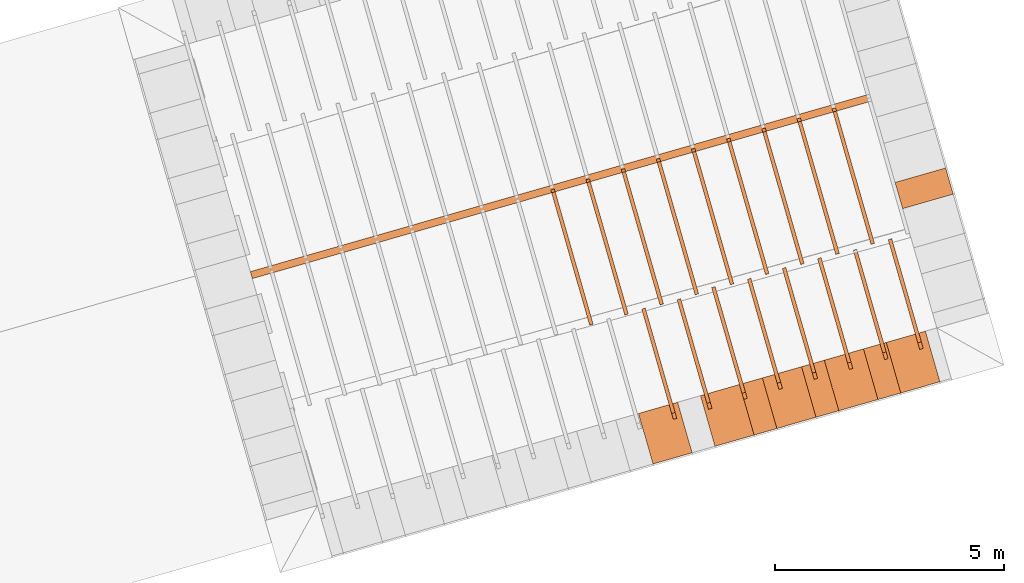
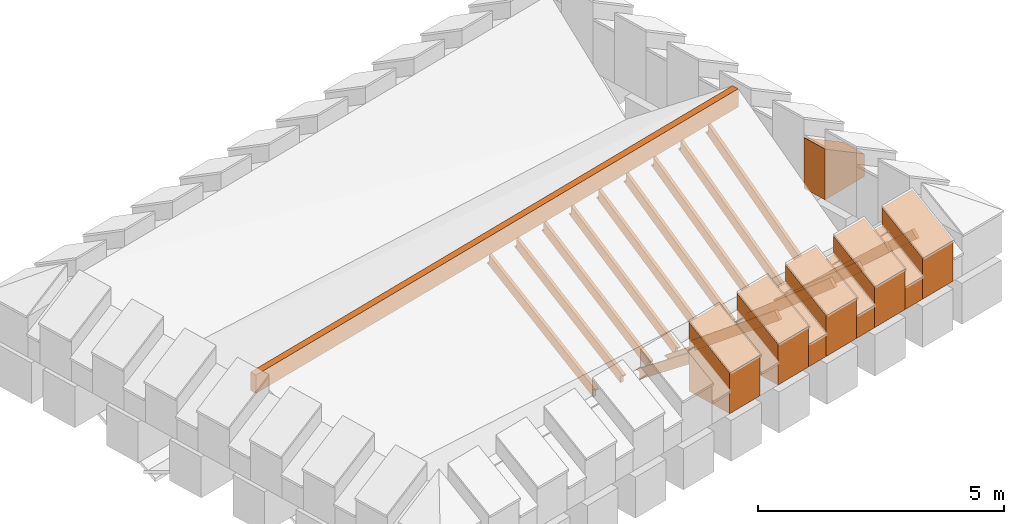
# One storey, part 8 of 10: 27 proxies.
"""IFC4 building model written with IfcOpenShell, lengths in metres."""

from ifc_helpers import new_model, entity, si_unit, converted_unit, derived_unit, direction, frame, origin_with_axes, place, context, subcontext, project, spatial, polygons, material, type_object, element, save


model = new_model("IFC4")

# Units and contexts
model_context = context("Model", 3, precision=1e-05, world=origin_with_axes(), true_north=direction((0.0, 1.0)))
body_context = subcontext(model_context, "Body", "Model", "MODEL_VIEW")
ifc_project = project(units=[si_unit("LENGTHUNIT", "METRE"), si_unit("AREAUNIT", "SQUARE_METRE"), si_unit("VOLUMEUNIT", "CUBIC_METRE"), converted_unit("PLANEANGLEUNIT", "DEGREE", entity("IfcPlaneAngleMeasure", 0.0174532925199433), si_unit("PLANEANGLEUNIT", "RADIAN"), dimensions=[0, 0, 0, 0, 0, 0, 0]), converted_unit("TIMEUNIT", "Year", entity("IfcTimeMeasure", 31557600.0), si_unit("TIMEUNIT", "SECOND"), dimensions=[0, 0, 1, 0, 0, 0, 0]), si_unit("MASSUNIT", "GRAM", prefix="KILO"), si_unit("THERMODYNAMICTEMPERATUREUNIT", "DEGREE_CELSIUS"), si_unit("LUMINOUSINTENSITYUNIT", "LUMEN"), si_unit("ENERGYUNIT", "JOULE", prefix="MEGA"), derived_unit("THERMALCONDUCTANCEUNIT", [(si_unit("POWERUNIT", "WATT"), 1), (si_unit("LENGTHUNIT", "METRE"), -1), (si_unit("THERMODYNAMICTEMPERATUREUNIT", "KELVIN"), -1)]), derived_unit("SPECIFICHEATCAPACITYUNIT", [(si_unit("ENERGYUNIT", "JOULE"), 1), (si_unit("MASSUNIT", "GRAM", prefix="KILO"), -1), (si_unit("THERMODYNAMICTEMPERATUREUNIT", "KELVIN"), -1)]), derived_unit("MASSDENSITYUNIT", [(si_unit("MASSUNIT", "GRAM", prefix="KILO"), 1), (si_unit("VOLUMEUNIT", "CUBIC_METRE"), -1)])], contexts=[model_context])

# Site, building, storey
site_placement = place(None, frame((0.0, 0.0, 0.0), z_axis=(0.0, 0.0, 1.0), x_axis=(0.9612616959383189, 0.2756373558169991, 0.0)))
site = spatial("IfcSite", under=ifc_project, at=site_placement, CompositionType="ELEMENT")
building_placement = place(site_placement, origin_with_axes())
building = spatial("IfcBuilding", under=site, at=building_placement, CompositionType="ELEMENT")
storey_placement = place(building_placement, frame((0.0, 0.0, 11.0), z_axis=(0.0, 0.0, 1.0), x_axis=(1.0, 0.0, 0.0)))
storey = spatial("IfcBuildingStorey", under=building, at=storey_placement, Name="Dach", CompositionType="ELEMENT", Elevation=11.0)

# Proxies
ifc_material_1 = material()
building_element_proxy_type_1 = type_object("IfcBuildingElementProxyType", PredefinedType="NOTDEFINED")
proxy_1_placement = place(storey_placement, frame((-32.66955969550476, -0.05131726657445945, -11.3285), z_axis=(0.0, 0.0, 1.0), x_axis=(1.0, 0.0, 0.0)))
element("IfcBuildingElementProxy", 1, at=proxy_1_placement, inside=storey, type_object=building_element_proxy_type_1, material=ifc_material_1, Name="008", PredefinedType="NOTDEFINED", context=body_context, shape_type="Tessellation", body=[
    polygons([(61.03241932296884, 7.381130212056575, 12.29306372087191), (61.03241932296884, 7.526718754969066, 12.458), (61.03241932296884, 9.89566501934427, 10.36694133970042), (61.03241932296885, 9.787341089745906, 10.36694133970042), (61.03241932296885, 9.787341089745906, 10.16911174696492), (61.11241932296884, 7.381130212056575, 12.29306372087191), (61.11241932296884, 7.526718754969066, 12.458), (61.11241932296884, 9.90232393687027, 10.36106354189202), (61.11241932296885, 9.787341089745906, 10.36106354189202), (61.11241932296885, 9.787341089745906, 10.16911174696491)], [[[1, 2, 3, 4, 5]], [[2, 1, 6, 7]], [[3, 2, 7, 8]], [[4, 3, 8, 9]], [[5, 4, 9, 10]], [[1, 5, 10, 6]], [[6, 10, 9, 8, 7]]], closed=True),
])
proxy_2_placement = place(storey_placement, frame((-32.66955969550476, -0.05131726657445945, -11.3285), z_axis=(0.0, 0.0, 1.0), x_axis=(1.0, 0.0, 0.0)))
element("IfcBuildingElementProxy", 2, at=proxy_2_placement, inside=storey, type_object=building_element_proxy_type_1, material=ifc_material_1, Name="008", PredefinedType="NOTDEFINED", context=body_context, shape_type="Tessellation", body=[
    polygons([(61.83241932296884, 7.37530678639323, 12.38177859929889), (61.83241932296884, 7.526718754969063, 12.5413856660973), (61.83241932296882, 9.862634373866781, 10.32540870856656), (61.83241932296882, 9.861835376853213, 10.30816336161642), (61.83241932296882, 9.787341089745906, 10.30816336161642), (61.83241932296882, 9.787341089745905, 10.09359130616137), (61.91241932296884, 7.375306786393231, 12.38177859929889), (61.91241932296884, 7.526718754969063, 12.5413856660973), (61.91241932296882, 9.862634373866783, 10.32540870856656), (61.91241932296882, 9.861563051633615, 10.30228556380802), (61.91241932296883, 9.787341089745906, 10.30228556380802), (61.91241932296882, 9.787341089745905, 10.09359130616137)], [[[1, 2, 3, 4, 5, 6]], [[2, 1, 7, 8]], [[3, 2, 8, 9]], [[4, 3, 9, 10]], [[5, 4, 10, 11]], [[6, 5, 11, 12]], [[1, 6, 12, 7]], [[7, 12, 11, 10, 9, 8]]], closed=True),
])
proxy_3_placement = place(storey_placement, frame((-32.66955969550476, -0.05131726657445945, -11.3285), z_axis=(0.0, 0.0, 1.0), x_axis=(1.0, 0.0, 0.0)))
element("IfcBuildingElementProxy", 3, at=proxy_3_placement, inside=storey, type_object=building_element_proxy_type_1, material=ifc_material_1, Name="008", PredefinedType="NOTDEFINED", context=body_context, shape_type="Tessellation", body=[
    polygons([(62.63241932296884, 7.377252049091295, 12.29656981746263), (62.63241932296884, 7.526718754969065, 12.458), (62.63241932296887, 9.871470519104868, 10.28701613082583), (62.63241932296887, 9.872561772591819, 10.24938538353242), (62.63241932296887, 9.787341089745906, 10.24938538353242), (62.63241932296887, 9.787341089745905, 10.065090771124), (62.71241932296884, 7.377252049091294, 12.29656981746263), (62.71241932296884, 7.526718754969064, 12.458), (62.71241932296887, 9.871470519104868, 10.28701613082583), (62.71241932296887, 9.872732222763963, 10.24350758572402), (62.71241932296893, 9.787341089745906, 10.24350758572401), (62.71241932296887, 9.787341089745905, 10.06509077112399)], [[[1, 2, 3, 4, 5, 6]], [[2, 1, 7, 8]], [[3, 2, 8, 9]], [[4, 3, 9, 10]], [[5, 4, 10, 11]], [[6, 5, 11, 12]], [[1, 6, 12, 7]], [[7, 12, 11, 10, 9, 8]]], closed=True),
])
proxy_4_placement = place(storey_placement, frame((-32.66955969550476, -0.05131726657445945, -11.3285), z_axis=(0.0, 0.0, 1.0), x_axis=(1.0, 0.0, 0.0)))
element("IfcBuildingElementProxy", 4, at=proxy_4_placement, inside=storey, type_object=building_element_proxy_type_1, material=ifc_material_1, Name="008", PredefinedType="NOTDEFINED", context=body_context, shape_type="Tessellation", body=[
    polygons([(60.23241932296884, 7.383753791211458, 12.29078451286503), (60.23241932296884, 7.526718754969066, 12.458), (60.23241932296884, 9.903726347177741, 10.42571931778442), (60.23241932296884, 9.787341089745906, 10.42571931778442), (60.23241932296884, 9.787341089745906, 10.23577886170872), (60.31241932296884, 7.383753791211458, 12.29078451286503), (60.31241932296884, 7.526718754969066, 12.458), (60.31241932296884, 9.910601170197168, 10.41984151997602), (60.31241932296884, 9.787341089745906, 10.41984151997602), (60.31241932296884, 9.787341089745906, 10.23577886170872)], [[[1, 2, 3, 4, 5]], [[2, 1, 6, 7]], [[3, 2, 7, 8]], [[4, 3, 8, 9]], [[5, 4, 9, 10]], [[1, 5, 10, 6]], [[6, 10, 9, 8, 7]]], closed=True),
])
proxy_5_placement = place(storey_placement, frame((-32.66955969550476, -0.05131726657445945, -11.3285), z_axis=(0.0, 0.0, 1.0), x_axis=(1.0, 0.0, 0.0)))
element("IfcBuildingElementProxy", 5, at=proxy_5_placement, inside=storey, type_object=building_element_proxy_type_1, material=ifc_material_1, Name="008", PredefinedType="NOTDEFINED", context=body_context, shape_type="Tessellation", body=[
    polygons([(59.43241932296884, 7.385575854858428, 12.28924372086243), (59.43241932296884, 7.526718754969064, 12.458), (59.43241932296884, 9.886320073605198, 10.48449729586842), (59.43241932296885, 9.787341089745905, 10.48449729586842), (59.43241932296885, 9.787341089745906, 10.28047632939507), (59.51241932296884, 7.385575854858428, 12.28924372086243), (59.51241932296884, 7.526718754969064, 12.458), (59.51241932296884, 9.893347811358149, 10.47861949806002), (59.51241932296885, 9.787341089745905, 10.47861949806002), (59.51241932296885, 9.787341089745906, 10.28047632939507)], [[[1, 2, 3, 4, 5]], [[2, 1, 6, 7]], [[3, 2, 7, 8]], [[4, 3, 8, 9]], [[5, 4, 9, 10]], [[1, 5, 10, 6]], [[6, 10, 9, 8, 7]]], closed=True),
])
proxy_6_placement = place(storey_placement, frame((-32.66955969550476, -0.05131726657445945, -11.3285), z_axis=(0.0, 0.0, 1.0), x_axis=(1.0, 0.0, 0.0)))
element("IfcBuildingElementProxy", 6, at=proxy_6_placement, inside=storey, type_object=building_element_proxy_type_1, material=ifc_material_1, Name="008", PredefinedType="NOTDEFINED", context=body_context, shape_type="Tessellation", body=[
    polygons([(58.63241932296884, 7.389549320189349, 12.28599841232647), (58.63241932296884, 7.526718754969065, 12.458), (58.63241932296884, 9.9276595576109, 10.54327527395242), (58.63241932296884, 9.787341089745905, 10.54327527395242), (58.63241932296884, 9.787341089745905, 10.37378500663502), (58.71241932296884, 7.389549320189349, 12.28599841232647), (58.71241932296884, 7.526718754969065, 12.458), (58.71241932296884, 9.935029935397266, 10.53739747614402), (58.71241932296884, 9.787341089745905, 10.53739747614402), (58.71241932296884, 9.787341089745905, 10.37378500663502)], [[[1, 2, 3, 4, 5]], [[2, 1, 6, 7]], [[3, 2, 7, 8]], [[4, 3, 8, 9]], [[5, 4, 9, 10]], [[1, 5, 10, 6]], [[7, 6, 10, 9, 8]]], closed=True),
])
proxy_7_placement = place(storey_placement, frame((-32.66955969550476, -0.05131726657445945, -11.3285), z_axis=(0.0, 0.0, 1.0), x_axis=(1.0, 0.0, 0.0)))
element("IfcBuildingElementProxy", 7, at=proxy_7_placement, inside=storey, type_object=building_element_proxy_type_1, material=ifc_material_1, Name="008", PredefinedType="NOTDEFINED", context=body_context, shape_type="Tessellation", body=[
    polygons([(57.83241932296884, 7.390572951635179, 12.28518703684454), (57.83241932296884, 7.526718754969064, 12.458), (57.83241932296884, 9.882514153140576, 10.60205325203643), (57.83241932296884, 9.787341089745905, 10.60205325203643), (57.83241932296884, 9.787341089745905, 10.39696107503057), (57.91241932296884, 7.390572951635179, 12.28518703684454), (57.91241932296884, 7.526718754969064, 12.458), (57.91241932296884, 9.889974975517944, 10.59617545422803), (57.91241932296884, 9.787341089745905, 10.59617545422803), (57.91241932296884, 9.787341089745905, 10.39696107503057)], [[[1, 2, 3, 4, 5]], [[2, 1, 6, 7]], [[3, 2, 7, 8]], [[4, 3, 8, 9]], [[5, 4, 9, 10]], [[1, 5, 10, 6]], [[6, 10, 9, 8, 7]]], closed=True),
])
proxy_8_placement = place(storey_placement, frame((-32.66955969550476, -0.05131726657445945, -11.3285), z_axis=(0.0, 0.0, 1.0), x_axis=(1.0, 0.0, 0.0)))
element("IfcBuildingElementProxy", 8, at=proxy_8_placement, inside=storey, type_object=building_element_proxy_type_1, material=ifc_material_1, Name="008", PredefinedType="NOTDEFINED", context=body_context, shape_type="Tessellation", body=[
    polygons([(57.03241932296884, 7.393757020753038, 12.28272542330884), (57.03241932296884, 7.526718754969065, 12.458), (57.03241932296884, 9.895806351791734, 10.66083123012043), (57.03241932296884, 9.787341089745905, 10.66083123012043), (57.03241932296884, 9.787341089745905, 10.46697384762017), (57.11241932296884, 7.393757020753038, 12.28272542330884), (57.11241932296884, 7.526718754969065, 12.458), (57.11241932296884, 9.90355466019654, 10.65495343231203), (57.11241932296884, 9.787341089745905, 10.65495343231203), (57.11241932296884, 9.787341089745905, 10.46697384762017)], [[[1, 2, 3, 4, 5]], [[2, 1, 6, 7]], [[3, 2, 7, 8]], [[4, 3, 8, 9]], [[5, 4, 9, 10]], [[1, 5, 10, 6]], [[6, 10, 9, 8, 7]]], closed=True),
])
proxy_9_placement = place(storey_placement, frame((79.48385070717022, 25.8856182236699, -11.3285), z_axis=(0.0, 0.0, 1.0), x_axis=(-1.0, 0.0, 0.0)))
element("IfcBuildingElementProxy", 9, at=proxy_9_placement, inside=storey, type_object=building_element_proxy_type_1, material=ifc_material_1, Name="003", PredefinedType="NOTDEFINED", context=body_context, shape_type="Tessellation", body=[
    polygons([(55.43241932244963, 13.0473410897459, 12.42240354413239), (55.43241932244962, 13.0473410897459, 12.642), (55.43241932244962, 16.05704587116529, 10.71221040876106), (55.43241932244962, 16.06016943486015, 10.68366000188212), (55.43241932244962, 15.9873410897459, 10.68366000188212), (55.43241932244962, 15.9873410897459, 10.49556478084415), (55.43241932244962, 12.98223842714421, 12.42240354413239), (55.51241932244962, 13.0473410897459, 12.42240354413239), (55.51241932244962, 13.0473410897459, 12.642), (55.51241932244962, 16.05704587116529, 10.71221040876106), (55.51241932244962, 16.05952637306709, 10.68953779969052), (55.51241932244965, 15.9873410897459, 10.68953779969052), (55.51241932244962, 15.9873410897459, 10.49556478084415), (55.51241932244962, 12.98223842714421, 12.42240354413239)], [[[1, 2, 3, 4, 5, 6, 7]], [[2, 1, 8, 9]], [[3, 2, 9, 10]], [[4, 3, 10, 11]], [[5, 4, 11, 12]], [[6, 5, 12, 13]], [[6, 13, 14, 7]], [[1, 7, 14, 8]], [[10, 9, 8, 14, 13, 12, 11]]], closed=True),
])
proxy_10_placement = place(storey_placement, frame((79.48385070717022, 25.8856182236699, -11.3285), z_axis=(0.0, 0.0, 1.0), x_axis=(-1.0, 0.0, 0.0)))
element("IfcBuildingElementProxy", 10, at=proxy_10_placement, inside=storey, type_object=building_element_proxy_type_1, material=ifc_material_1, Name="003", PredefinedType="NOTDEFINED", context=body_context, shape_type="Tessellation", body=[
    polygons([(52.23241932244962, 15.9873410897459, 10.24879059796566), (52.31241932244962, 15.9873410897459, 10.24879059796566), (52.31241932244962, 12.97568312696457, 12.42240354413239), (52.23241932244962, 12.97568312696457, 12.42240354413239), (52.23241932244962, 15.9873410897459, 10.44854808954612), (52.31241932244964, 15.9873410897459, 10.45442588735452), (52.31241932244962, 16.05704587116523, 10.46979672928334), (52.31241932244962, 13.0473410897459, 12.642), (52.31241932244962, 13.0473410897459, 12.42240354413239), (52.31241932244962, 16.05787615879391, 10.45442588735452), (52.23241932244967, 13.0473410897459, 12.42240354413239), (52.23241932244962, 13.0473410897459, 12.642), (52.23241932244962, 16.05704587116523, 10.46979672928334), (52.23241932244962, 16.05819366012707, 10.44854808954612)], [[[1, 2, 3, 4]], [[1, 5, 6, 2]], [[7, 8, 9, 3, 2, 6, 10]], [[11, 4, 3, 9]], [[11, 12, 13, 14, 5, 1, 4]], [[5, 14, 10, 6]], [[13, 12, 8, 7]], [[12, 11, 9, 8]], [[14, 13, 7, 10]]], closed=True),
])
proxy_11_placement = place(storey_placement, frame((79.48385070717022, 25.8856182236699, -11.3285), z_axis=(0.0, 0.0, 1.0), x_axis=(-1.0, 0.0, 0.0)))
element("IfcBuildingElementProxy", 11, at=proxy_11_placement, inside=storey, type_object=building_element_proxy_type_1, material=ifc_material_1, Name="003", PredefinedType="NOTDEFINED", context=body_context, shape_type="Tessellation", body=[
    polygons([(49.83241932244962, 15.9873410897459, 10.213), (49.83241932244962, 15.7968381574803, 10.213), (49.83241932244962, 12.97102857594039, 12.42240354413239), (49.83241932244954, 13.0473410897459, 12.42240354413239), (49.83241932244962, 13.0473410897459, 12.642), (49.83241932244962, 16.05704587116517, 10.28881510944665), (49.83241932244962, 16.05730391812493, 10.27221415529412), (49.83241932244962, 15.9873410897459, 10.27221415529412), (49.91241932244962, 15.7968381574803, 10.213), (49.91241932244963, 15.9873410897459, 10.213), (49.91241932244962, 12.97102857594039, 12.42240354413239), (49.91241932244962, 13.0473410897459, 12.42240354413239), (49.91241932244962, 13.0473410897459, 12.642), (49.91241932244962, 16.05704587116517, 10.28881510944665), (49.91241932244962, 16.05721255302382, 10.27809195310251), (49.91241932244964, 15.9873410897459, 10.27809195310252)], [[[1, 2, 3, 4, 5, 6, 7, 8]], [[9, 2, 1, 10]], [[2, 9, 11, 3]], [[12, 4, 3, 11]], [[13, 5, 4, 12]], [[6, 5, 13, 14]], [[7, 6, 14, 15]], [[8, 7, 15, 16]], [[1, 8, 16, 10]], [[10, 16, 15, 14, 13, 12, 11, 9]]], closed=True),
])
proxy_12_placement = place(storey_placement, frame((79.48385070717022, 25.8856182236699, -11.3285), z_axis=(0.0, 0.0, 1.0), x_axis=(-1.0, 0.0, 0.0)))
element("IfcBuildingElementProxy", 12, at=proxy_12_placement, inside=storey, type_object=building_element_proxy_type_1, material=ifc_material_1, Name="003", PredefinedType="NOTDEFINED", context=body_context, shape_type="Tessellation", body=[
    polygons([(54.63241932244966, 13.0473410897459, 12.42240354413239), (54.63241932244962, 13.0473410897459, 12.642), (54.63241932244962, 16.05704587116528, 10.65813585979772), (54.63241932244962, 16.06025960763651, 10.62488202379812), (54.63241932244962, 15.9873410897459, 10.62488202379812), (54.63241932244962, 15.9873410897459, 10.440588075492), (54.63241932244962, 12.98074433194067, 12.42240354413239), (54.71241932244962, 13.0473410897459, 12.42240354413239), (54.71241932244962, 13.0473410897459, 12.642), (54.71241932244962, 16.05704587116528, 10.65813585979772), (54.71241932244962, 16.05969156209772, 10.63075982160652), (54.71241932244962, 15.9873410897459, 10.63075982160652), (54.71241932244962, 15.9873410897459, 10.440588075492), (54.71241932244962, 12.98074433194067, 12.42240354413239)], [[[1, 2, 3, 4, 5, 6, 7]], [[2, 1, 8, 9]], [[3, 2, 9, 10]], [[4, 3, 10, 11]], [[5, 4, 11, 12]], [[6, 5, 12, 13]], [[6, 13, 14, 7]], [[1, 7, 14, 8]], [[10, 9, 8, 14, 13, 12, 11]]], closed=True),
])
proxy_13_placement = place(storey_placement, frame((79.48385070717022, 25.8856182236699, -11.3285), z_axis=(0.0, 0.0, 1.0), x_axis=(-1.0, 0.0, 0.0)))
element("IfcBuildingElementProxy", 13, at=proxy_13_placement, inside=storey, type_object=building_element_proxy_type_1, material=ifc_material_1, Name="003", PredefinedType="NOTDEFINED", context=body_context, shape_type="Tessellation", body=[
    polygons([(53.83241932244963, 13.0473410897459, 12.42240354413239), (53.83241932244962, 13.0473410897459, 12.642), (53.83241932244962, 16.05704587116526, 10.58173912076317), (53.83241932244962, 16.05828132135308, 10.56610404571412), (53.83241932244962, 15.9873410897459, 10.56610404571412), (53.83241932244962, 15.9873410897459, 10.36284655167166), (53.83241932244962, 12.97866457198798, 12.42240354413239), (53.91241932244962, 13.0473410897459, 12.42240354413239), (53.91241932244962, 13.0473410897459, 12.642), (53.91241932244962, 16.05704587116526, 10.58173912076317), (53.91241932244962, 16.05781687034254, 10.57198184352252), (53.91241932244963, 15.9873410897459, 10.57198184352252), (53.91241932244962, 15.9873410897459, 10.36284655167166), (53.91241932244962, 12.97866457198798, 12.42240354413239)], [[[1, 2, 3, 4, 5, 6, 7]], [[2, 1, 8, 9]], [[3, 2, 9, 10]], [[4, 3, 10, 11]], [[5, 4, 11, 12]], [[6, 5, 12, 13]], [[6, 13, 14, 7]], [[1, 7, 14, 8]], [[10, 9, 8, 14, 13, 12, 11]]], closed=True),
])
proxy_14_placement = place(storey_placement, frame((79.48385070717022, 25.8856182236699, -11.3285), z_axis=(0.0, 0.0, 1.0), x_axis=(-1.0, 0.0, 0.0)))
element("IfcBuildingElementProxy", 14, at=proxy_14_placement, inside=storey, type_object=building_element_proxy_type_1, material=ifc_material_1, Name="003", PredefinedType="NOTDEFINED", context=body_context, shape_type="Tessellation", body=[
    polygons([(50.63241932244962, 15.9873410897459, 10.213), (50.63241932244962, 15.88094991388374, 10.213), (50.63241932244962, 12.97271999412028, 12.42240354413239), (50.63241932244962, 13.0473410897459, 12.42240354413239), (50.63241932244962, 13.0473410897459, 12.642), (50.63241932244962, 16.05704587116519, 10.35550526116538), (50.63241932244962, 16.05776782380472, 10.33099213337812), (50.63241932244962, 15.9873410897459, 10.33099213337812), (50.71241932244962, 15.88094991388374, 10.213), (50.71241932244963, 15.9873410897459, 10.213), (50.71241932244962, 12.97271999412028, 12.42240354413239), (50.71241932244962, 13.0473410897459, 12.42240354413239), (50.71241932244962, 13.0473410897459, 12.642), (50.71241932244962, 16.05704587116519, 10.35550526116538), (50.71241932244962, 16.05759471282193, 10.33686993118652), (50.71241932244963, 15.9873410897459, 10.33686993118652)], [[[1, 2, 3, 4, 5, 6, 7, 8]], [[9, 2, 1, 10]], [[2, 9, 11, 3]], [[12, 4, 3, 11]], [[4, 12, 13, 5]], [[6, 5, 13, 14]], [[7, 6, 14, 15]], [[8, 7, 15, 16]], [[1, 8, 16, 10]], [[10, 16, 15, 14, 13, 12, 11, 9]]], closed=True),
])
proxy_15_placement = place(storey_placement, frame((79.48385070717022, 25.8856182236699, -11.3285), z_axis=(0.0, 0.0, 1.0), x_axis=(-1.0, 0.0, 0.0)))
element("IfcBuildingElementProxy", 15, at=proxy_15_placement, inside=storey, type_object=building_element_proxy_type_1, material=ifc_material_1, Name="003", PredefinedType="NOTDEFINED", context=body_context, shape_type="Tessellation", body=[
    polygons([(53.03241932244962, 15.9873410897459, 10.32102670754271), (53.11241932244962, 15.9873410897459, 10.32102670754271), (53.11241932244962, 12.97756177222931, 12.42240354413239), (53.03241932244962, 12.97756177222931, 12.42240354413239), (53.03241932244962, 15.9873410897459, 10.50732606763012), (53.11241932244957, 15.9873410897459, 10.51320386543852), (53.11241932244962, 16.05704587116524, 10.54067520324821), (53.11241932244962, 13.0473410897459, 12.642), (53.11241932244962, 13.0473410897459, 12.42240354413239), (53.11241932244962, 16.05896159299123, 10.51320386543852), (53.03241932244961, 13.0473410897459, 12.42240354413239), (53.03241932244962, 13.0473410897459, 12.642), (53.03241932244962, 16.05704587116524, 10.54067520324821), (53.03241932244962, 16.05937148295102, 10.50732606763012)], [[[1, 2, 3, 4]], [[1, 5, 6, 2]], [[7, 8, 9, 3, 2, 6, 10]], [[11, 4, 3, 9]], [[11, 12, 13, 14, 5, 1, 4]], [[5, 14, 10, 6]], [[13, 12, 8, 7]], [[12, 11, 9, 8]], [[14, 13, 7, 10]]], closed=True),
])
proxy_16_placement = place(storey_placement, frame((79.48385070717022, 25.8856182236699, -11.3285), z_axis=(0.0, 0.0, 1.0), x_axis=(-1.0, 0.0, 0.0)))
element("IfcBuildingElementProxy", 16, at=proxy_16_placement, inside=storey, type_object=building_element_proxy_type_1, material=ifc_material_1, Name="003", PredefinedType="NOTDEFINED", context=body_context, shape_type="Tessellation", body=[
    polygons([(51.43241932244962, 15.9873410897459, 10.213), (51.43241932244962, 15.96714171073835, 10.213), (51.43241932244962, 12.97438427181221, 12.42240354413239), (51.43241932244961, 13.0473410897459, 12.42240354413239), (51.43241932244962, 13.0473410897459, 12.642), (51.43241932244962, 16.05704587116521, 10.4200850782058), (51.43241932244962, 16.05835597052995, 10.38977011146212), (51.43241932244962, 15.9873410897459, 10.38977011146212), (51.51241932244962, 15.96714171073835, 10.213), (51.51241932244962, 15.9873410897459, 10.213), (51.51241932244962, 12.97438427181221, 12.42240354413239), (51.51241932244962, 13.0473410897459, 12.42240354413239), (51.51241932244962, 13.0473410897459, 12.642), (51.51241932244962, 16.05704587116521, 10.4200850782058), (51.51241932244962, 16.05810195411489, 10.39564790927052), (51.5124193224496, 15.9873410897459, 10.39564790927052)], [[[1, 2, 3, 4, 5, 6, 7, 8]], [[9, 2, 1, 10]], [[2, 9, 11, 3]], [[12, 4, 3, 11]], [[4, 12, 13, 5]], [[6, 5, 13, 14]], [[7, 6, 14, 15]], [[8, 7, 15, 16]], [[1, 8, 16, 10]], [[10, 16, 15, 14, 13, 12, 11, 9]]], closed=True),
])
proxy_17_placement = place(storey_placement, frame((79.48385070717022, 25.8856182236699, -11.3285), z_axis=(0.0, 0.0, 1.0), x_axis=(-1.0, 0.0, 0.0)))
element("IfcBuildingElementProxy", 17, at=proxy_17_placement, inside=storey, type_object=building_element_proxy_type_1, material=ifc_material_1, Name="003", PredefinedType="NOTDEFINED", context=body_context, shape_type="Tessellation", body=[
    polygons([(56.23241932244962, 13.0473410897459, 12.42240354413239), (56.23241932244962, 13.0473410897459, 12.642), (56.23241932244962, 16.05704587116531, 10.7626932038078), (56.23241932244962, 16.05950773769253, 10.74243797996612), (56.23241932244962, 15.9873410897459, 10.74243797996612), (56.23241932244962, 15.9873410897459, 10.54685159078951), (56.23241932244962, 12.98364967905431, 12.42240354413239), (56.31241932244962, 13.0473410897459, 12.42240354413239), (56.31241932244962, 13.0473410897459, 12.642), (56.31241932244962, 16.05704587116531, 10.7626932038078), (56.31241932244962, 16.05879333661796, 10.74831577777453), (56.31241932244962, 15.9873410897459, 10.74831577777453), (56.31241932244962, 15.9873410897459, 10.54685159078951), (56.31241932244962, 12.98364967905431, 12.42240354413239)], [[[1, 2, 3, 4, 5, 6, 7]], [[2, 1, 8, 9]], [[3, 2, 9, 10]], [[4, 3, 10, 11]], [[5, 4, 11, 12]], [[6, 5, 12, 13]], [[6, 13, 14, 7]], [[1, 7, 14, 8]], [[10, 9, 8, 14, 13, 12, 11]]], closed=True),
])
ifc_material_2 = material(Name="Aluminium")
building_element_proxy_type_2 = type_object("IfcBuildingElementProxyType", Name="Aluminium", PredefinedType="NOTDEFINED")
proxy_18_placement = place(storey_placement, frame((16.3628611917876, 12.99602382325407, 1.313499999999999), z_axis=(0.0, 0.0, 1.0), x_axis=(1.0, 0.0, 0.0)))
element("IfcBuildingElementProxy", 18, at=proxy_18_placement, inside=storey, type_object=building_element_proxy_type_2, material=ifc_material_2, Name="001", PredefinedType="NOTDEFINED", context=body_context, shape_type="Tessellation", body=[
    polygons([(0.0, -0.1600000000826221, 0.0), (14.08857514171309, -0.1600000000826221, 0.0), (14.08857514171309, -0.1600000000826221, 0.4521338064115614), (0.0, -0.1600000000826221, 0.4521338064115614), (0.0, 0.0, 0.0), (14.08857514171309, 0.0, 0.0), (14.08857514171309, 0.0, 0.4521338064115614), (0.0, 0.0, 0.4521338064115614)], [[[1, 2, 3, 4]], [[1, 5, 6, 2]], [[2, 6, 7, 3]], [[8, 4, 3, 7]], [[5, 1, 4, 8]], [[6, 5, 8, 7]]], closed=True),
])
ifc_material_3 = material()
building_element_proxy_type_3 = type_object("IfcBuildingElementProxyType", Name="519 x 1150", PredefinedType="NOTDEFINED")
proxy_19_placement = place(storey_placement, frame((26.22507181224712, 7.100401480447987, 0.2019994076779703), z_axis=(0.0, 0.0, 1.0), x_axis=(1.0, 0.0, 0.0)))
element("IfcBuildingElementProxy", 19, at=proxy_19_placement, inside=storey, type_object=building_element_proxy_type_3, material=ifc_material_3, PredefinedType="NOTDEFINED", context=body_context, shape_type="Tessellation", body=[
    polygons([(-0.2594837734777755, -0.5749999999999993, 0.5616599571312832), (-0.2594837734777755, -0.5749999999999993, 0.0), (0.2594837734777826, -0.5750000000000002, 0.0), (0.2594837734777826, -0.5750000000000002, 0.5616599571312832), (-0.2594837734777791, 0.5750000000000011, 1.258340042868717), (-0.2594837734777791, 0.5750000000000011, 0.0), (0.2594837734777791, 0.5750000000000002, 0.0), (0.2594837734777791, 0.5750000000000002, 1.258340042868717)], [[[1, 2, 3, 4]], [[5, 6, 2, 1]], [[3, 2, 6, 7]], [[4, 3, 7, 8]], [[5, 1, 4, 8]], [[8, 7, 6, 5]]], closed=True),
])
proxy_20_placement = place(storey_placement, frame((29.04296798608734, 7.100401487404371, 0.2019994076779703), z_axis=(0.0, 0.0, 1.0), x_axis=(1.0, 0.0, 0.0)))
element("IfcBuildingElementProxy", 20, at=proxy_20_placement, inside=storey, type_object=building_element_proxy_type_3, material=ifc_material_3, PredefinedType="NOTDEFINED", context=body_context, shape_type="Tessellation", body=[
    polygons([(-0.2594999999999992, -0.5750000000000002, 0.5616599571312832), (-0.2594999999999992, -0.5750000000000002, 0.0), (0.2595000000000027, -0.5750000000000011, 0.0), (0.2595000000000027, -0.5750000000000011, 0.5616599571312832), (-0.2594999999999992, 0.5750000000000002, 1.258340042868717), (-0.2594999999999992, 0.5750000000000002, 0.0), (0.2595000000000027, 0.5749999999999993, 0.0), (0.2595000000000027, 0.5749999999999993, 1.258340042868717)], [[[1, 2, 3, 4]], [[5, 6, 2, 1]], [[3, 2, 6, 7]], [[4, 3, 7, 8]], [[5, 1, 4, 8]], [[8, 7, 6, 5]]], closed=True),
])
proxy_21_placement = place(storey_placement, frame((27.63400714968108, 7.100401487404371, 0.2019994076779703), z_axis=(0.0, 0.0, 1.0), x_axis=(1.0, 0.0, 0.0)))
element("IfcBuildingElementProxy", 21, at=proxy_21_placement, inside=storey, type_object=building_element_proxy_type_3, material=ifc_material_3, PredefinedType="NOTDEFINED", context=body_context, shape_type="Tessellation", body=[
    polygons([(-0.259458274711001, -0.5749999999999993, 0.5616599571312832), (-0.259458274711001, -0.5749999999999993, 0.0), (0.2594582747110046, -0.5750000000000002, 0.0), (0.2594582747110046, -0.5750000000000002, 0.5616599571312832), (-0.259458274711001, 0.5750000000000011, 1.258340042868717), (-0.259458274711001, 0.5750000000000011, 0.0), (0.2594582747110046, 0.5750000000000002, 0.0), (0.2594582747110046, 0.5750000000000002, 1.258340042868717)], [[[1, 2, 3, 4]], [[5, 6, 2, 1]], [[3, 2, 6, 7]], [[4, 3, 7, 8]], [[5, 1, 4, 8]], [[8, 7, 6, 5]]], closed=True),
])
building_element_proxy_type_4 = type_object("IfcBuildingElementProxyType", Name="596 x 1150", PredefinedType="NOTDEFINED")
proxy_22_placement = place(storey_placement, frame((31.02643138499301, 10.6864151176789, 0.2019994076779685), z_axis=(0.0, 0.0, 1.0), x_axis=(0.0, 1.0, 0.0)))
element("IfcBuildingElementProxy", 22, at=proxy_22_placement, inside=storey, type_object=building_element_proxy_type_4, material=ifc_material_3, PredefinedType="NOTDEFINED", context=body_context, shape_type="Tessellation", body=[
    polygons([(-0.2981999999999996, -0.5749999999999957, 0.5616599571312832), (-0.2981999999999996, -0.5749999999999957, 0.0), (0.2981999999999996, -0.5749999999999993, 0.0), (0.2981999999999996, -0.5749999999999993, 0.5616599571312832), (-0.2981999999999996, 0.5750000000000028, 1.258340042868717), (-0.2981999999999996, 0.5750000000000028, 0.0), (0.2981999999999996, 0.5749999999999993, 0.0), (0.2981999999999996, 0.5749999999999993, 1.258340042868717)], [[[1, 2, 3, 4]], [[5, 6, 2, 1]], [[3, 2, 6, 7]], [[4, 3, 7, 8]], [[5, 1, 4, 8]], [[8, 7, 6, 5]]], closed=True),
])
building_element_proxy_type_5 = type_object("IfcBuildingElementProxyType", Name="890 x 1150", PredefinedType="NOTDEFINED")
proxy_23_placement = place(storey_placement, frame((28.33846670523972, 7.100401487404371, 0.2019994076779703), z_axis=(0.0, 0.0, 1.0), x_axis=(1.0, 0.0, 0.0)))
element("IfcBuildingElementProxy", 23, at=proxy_23_placement, inside=storey, type_object=building_element_proxy_type_5, material=ifc_material_3, PredefinedType="NOTDEFINED", context=body_context, shape_type="Tessellation", body=[
    polygons([(-0.4450012808476238, -0.5749999999999993, 1.011659957131284), (-0.4450012808476238, -0.5749999999999993, 0.0), (0.4450012808476238, -0.5750000000000002, 0.0), (0.4450012808476238, -0.5750000000000002, 1.011659957131284), (-0.4450012808476238, 0.5750000000000002, 1.708340042868718), (-0.4450012808476238, 0.5750000000000002, 0.0), (0.4450012808476238, 0.5749999999999993, 0.0), (0.4450012808476238, 0.5749999999999993, 1.708340042868718)], [[[1, 2, 3, 4]], [[5, 6, 2, 1]], [[3, 2, 6, 7]], [[4, 3, 7, 8]], [[5, 1, 4, 8]], [[8, 7, 6, 5]]], closed=True),
])
proxy_24_placement = place(storey_placement, frame((29.74746926693496, 7.100401487404371, 0.2019994076779703), z_axis=(0.0, 0.0, 1.0), x_axis=(1.0, 0.0, 0.0)))
element("IfcBuildingElementProxy", 24, at=proxy_24_placement, inside=storey, type_object=building_element_proxy_type_5, material=ifc_material_3, PredefinedType="NOTDEFINED", context=body_context, shape_type="Tessellation", body=[
    polygons([(-0.4450012808476238, -0.5750000000000002, 1.011659957131284), (-0.4450012808476238, -0.5750000000000002, 0.0), (0.4450012808476238, -0.5750000000000002, 0.0), (0.4450012808476238, -0.5750000000000002, 1.011659957131284), (-0.4450012808476238, 0.5749999999999993, 1.708340042868718), (-0.4450012808476238, 0.5749999999999993, 0.0), (0.4450012808476238, 0.5749999999999993, 0.0), (0.4450012808476238, 0.5749999999999993, 1.708340042868718)], [[[1, 2, 3, 4]], [[5, 6, 2, 1]], [[3, 2, 6, 7]], [[4, 3, 7, 8]], [[5, 1, 4, 8]], [[8, 7, 6, 5]]], closed=True),
])
proxy_25_placement = place(storey_placement, frame((26.92954759426971, 7.100401481143626, 0.2019994076779703), z_axis=(0.0, 0.0, 1.0), x_axis=(1.0, 0.0, 0.0)))
element("IfcBuildingElementProxy", 25, at=proxy_25_placement, inside=storey, type_object=building_element_proxy_type_5, material=ifc_material_3, PredefinedType="NOTDEFINED", context=body_context, shape_type="Tessellation", body=[
    polygons([(-0.4450012808476238, -0.5749999999999993, 1.011659957131284), (-0.4450012808476238, -0.5749999999999993, 0.0), (0.4450012808476238, -0.5750000000000002, 0.0), (0.4450012808476238, -0.5750000000000002, 1.011659957131284), (-0.4450012808476238, 0.5750000000000002, 1.708340042868718), (-0.4450012808476238, 0.5750000000000002, 0.0), (0.4450012808476238, 0.5749999999999993, 0.0), (0.4450012808476238, 0.5749999999999993, 1.708340042868718)], [[[1, 2, 3, 4]], [[5, 6, 2, 1]], [[3, 2, 6, 7]], [[4, 3, 7, 8]], [[5, 1, 4, 8]], [[8, 7, 6, 5]]], closed=True),
])
proxy_26_placement = place(storey_placement, frame((25.5205867579371, 7.100401478013255, 0.2019994076779703), z_axis=(0.0, 0.0, 1.0), x_axis=(1.0, 0.0, 0.0)))
element("IfcBuildingElementProxy", 26, at=proxy_26_placement, inside=storey, type_object=building_element_proxy_type_5, material=ifc_material_3, PredefinedType="NOTDEFINED", context=body_context, shape_type="Tessellation", body=[
    polygons([(-0.4450012808476238, -0.5749999999999993, 1.011659957131284), (-0.4450012808476238, -0.5749999999999993, 0.0), (0.4450012808476238, -0.5749999999999993, 0.0), (0.4450012808476238, -0.5749999999999993, 1.011659957131284), (-0.4450012808476238, 0.5750000000000002, 1.708340042868718), (-0.4450012808476238, 0.5750000000000002, 0.0), (0.4450012808476238, 0.5750000000000002, 0.0), (0.4450012808476238, 0.5750000000000002, 1.708340042868718)], [[[1, 2, 3, 4]], [[5, 6, 2, 1]], [[3, 2, 6, 7]], [[4, 3, 7, 8]], [[5, 1, 4, 8]], [[8, 7, 6, 5]]], closed=True),
])
proxy_27_placement = place(storey_placement, frame((24.11162592160448, 7.100401474882881, 0.2019994076779703), z_axis=(0.0, 0.0, 1.0), x_axis=(1.0, 0.0, 0.0)))
element("IfcBuildingElementProxy", 27, at=proxy_27_placement, inside=storey, type_object=building_element_proxy_type_5, material=ifc_material_3, PredefinedType="NOTDEFINED", context=body_context, shape_type="Tessellation", body=[
    polygons([(-0.4450012808476238, -0.5750000000000002, 1.011659957131284), (-0.4450012808476238, -0.5750000000000002, 0.0), (0.4450012808476238, -0.5750000000000002, 0.0), (0.4450012808476238, -0.5750000000000002, 1.011659957131284), (-0.4450012808476238, 0.5749999999999993, 1.708340042868718), (-0.4450012808476238, 0.5749999999999993, 0.0), (0.4450012808476238, 0.5749999999999993, 0.0), (0.4450012808476238, 0.5749999999999993, 1.708340042868718)], [[[1, 2, 3, 4]], [[5, 6, 2, 1]], [[3, 2, 6, 7]], [[4, 3, 7, 8]], [[5, 1, 4, 8]], [[8, 7, 6, 5]]], closed=True),
])

save(model, "model.ifc")
